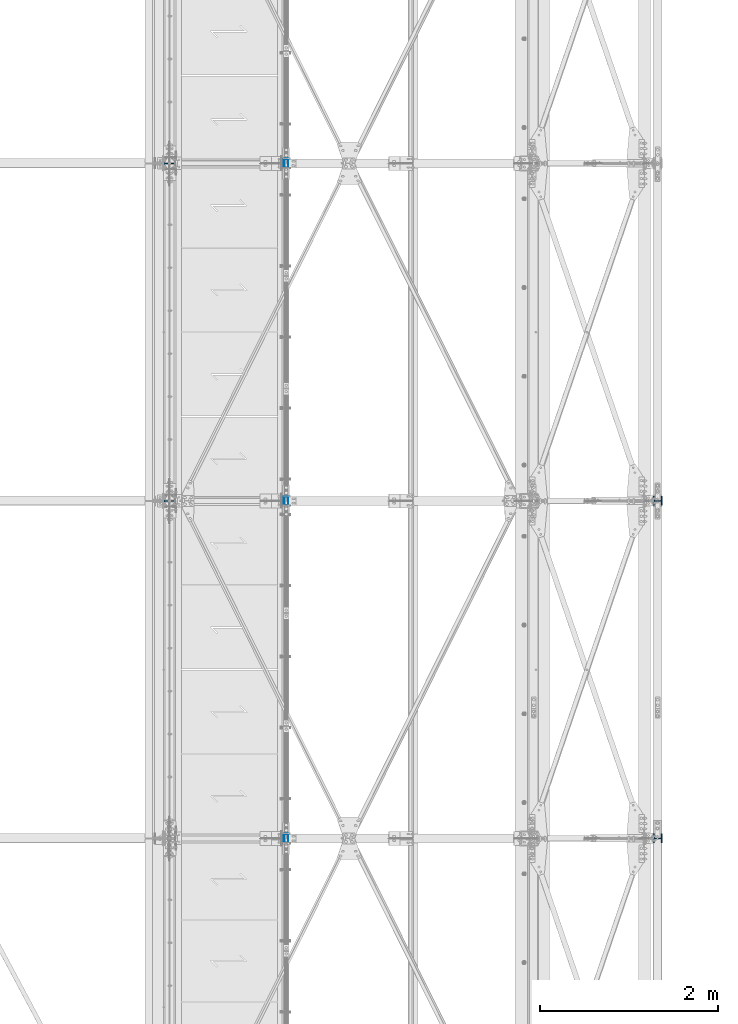
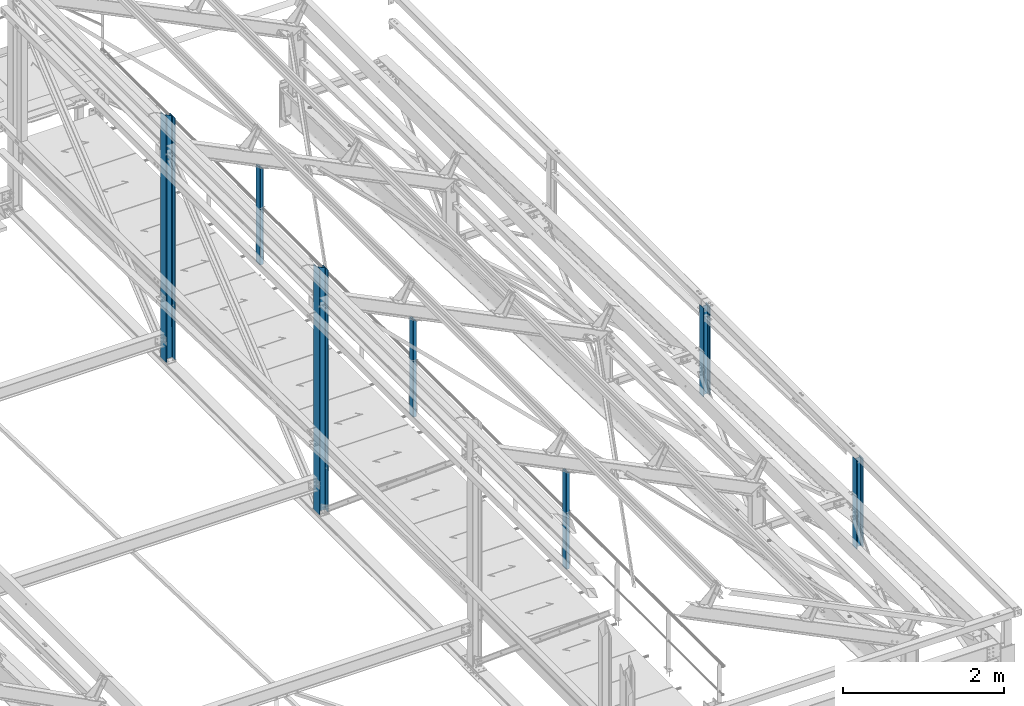
# One storey, part 17 of 496: 7 columns, 7 elements without a shape of their own.
"""IFC2X3 building model written with IfcOpenShell, lengths in millimetres."""

from ifc_helpers import new_model, si_unit, frame, origin_with_axes, origin_2d_with_axis, place, context, subcontext, project, spatial, hollow_rectangle, i_section, extrude, clip, halfspace, material, type_object, element, aggregate, save


model = new_model("IFC2X3")

# Units and contexts
model_context = context("Model", 3, precision=1e-05, world=origin_with_axes())
body_context = subcontext(model_context, "Body", "Model", "MODEL_VIEW")
ifc_project = project(units=[si_unit("LENGTHUNIT", "METRE", prefix="MILLI"), si_unit("AREAUNIT", "SQUARE_METRE"), si_unit("VOLUMEUNIT", "CUBIC_METRE"), si_unit("MASSUNIT", "GRAM", prefix="KILO"), si_unit("TIMEUNIT", "SECOND"), si_unit("PLANEANGLEUNIT", "RADIAN"), si_unit("SOLIDANGLEUNIT", "STERADIAN"), si_unit("THERMODYNAMICTEMPERATUREUNIT", "DEGREE_CELSIUS"), si_unit("LUMINOUSINTENSITYUNIT", "LUMEN")], contexts=[model_context])

# Site, building, storey
site_placement = place(None, origin_with_axes())
site = spatial("IfcSite", under=ifc_project, at=site_placement, CompositionType="ELEMENT")
building_placement = place(site_placement, origin_with_axes())
building = spatial("IfcBuilding", under=site, at=building_placement, Name="Undefined", CompositionType="ELEMENT")
storey_placement = place(building_placement, origin_with_axes())
storey = spatial("IfcBuildingStorey", under=building, at=storey_placement, Name="Undefined", CompositionType="ELEMENT", Elevation=0.0)

# Assembly, column
assembly_1_placement = place(storey_placement, origin_with_axes())
assembly_1 = element("IfcElementAssembly", 1, at=assembly_1_placement, inside=storey, Name="MONTANT", AssemblyPlace="NOTDEFINED", PredefinedType="NOTDEFINED")
ifc_material_1 = material(Name="Undefined/S275-E28")
column_type_1 = type_object("IfcColumnType", Name="HEA140", PredefinedType="NOTDEFINED")
column_1_placement = place(assembly_1_placement, frame((34280.0, 11400.0, 7260.0), z_axis=(0.0, 0.0, 1.0), x_axis=(-1.0, 0.0, 0.0)))
column_1 = element("IfcColumn", 2, at=column_1_placement, type_object=column_type_1, material=ifc_material_1, Name="MONTANT", ObjectType="HEA140", context=body_context, shape_type="Clipping", body=[
    clip(extrude(i_section(OverallWidth=140.0, OverallDepth=133.0, WebThickness=5.5, FlangeThickness=8.5, FilletRadius=12.0, at=origin_2d_with_axis()), frame((0.0, 0.0, 3730.84210522584), z_axis=(0.0, 0.0, -1.0), x_axis=(0.0, 1.0, 0.0)), (0.0, 0.0, 1.0), 3730.84), halfspace(frame((-66.5, 70.0, 3654.3071165161), z_axis=(-0.441220937981244, -6.28179308850765e-09, 0.89739850896185), x_axis=(0.89739850896185, 0.0, 0.441220937981244)), False)),
])
aggregate(assembly_1, [column_1])

assembly_2_placement = place(storey_placement, origin_with_axes())
assembly_2 = element("IfcElementAssembly", 3, at=assembly_2_placement, inside=storey, Name="MONTANT", AssemblyPlace="NOTDEFINED", PredefinedType="NOTDEFINED")
column_2_placement = place(assembly_2_placement, frame((34280.0, 7600.0, 7260.0), z_axis=(0.0, 0.0, 1.0), x_axis=(-1.0, 0.0, 0.0)))
column_2 = element("IfcColumn", 4, at=column_2_placement, type_object=column_type_1, material=ifc_material_1, Name="MONTANT", ObjectType="HEA140", context=body_context, shape_type="Clipping", body=[
    clip(extrude(i_section(OverallWidth=140.0, OverallDepth=133.0, WebThickness=5.5, FlangeThickness=8.5, FilletRadius=12.0, at=origin_2d_with_axis()), frame((0.0, 0.0, 3730.84210522584), z_axis=(0.0, 0.0, -1.0), x_axis=(0.0, 1.0, 0.0)), (0.0, 0.0, 1.0), 3730.84), halfspace(frame((-66.5, 70.0, 3654.3071165161), z_axis=(-0.441220937981244, -6.28179308850765e-09, 0.89739850896185), x_axis=(0.89739850896185, 0.0, 0.441220937981244)), False)),
])
aggregate(assembly_2, [column_2])

assembly_3_placement = place(storey_placement, origin_with_axes())
assembly_3 = element("IfcElementAssembly", 5, at=assembly_3_placement, inside=storey, AssemblyPlace="NOTDEFINED", PredefinedType="NOTDEFINED")
column_type_2 = type_object("IfcColumnType", Name="HEA100", PredefinedType="NOTDEFINED")
column_3_placement = place(assembly_3_placement, frame((39777.0, 3800.0, 7100.00000925125), z_axis=(0.0, 0.0, 1.0), x_axis=(1.0, 0.0, 0.0)))
column_3 = element("IfcColumn", 6, at=column_3_placement, type_object=column_type_2, material=ifc_material_1, ObjectType="HEA100", context=body_context, shape_type="SweptSolid", body=[
    extrude(i_section(OverallWidth=100.0, OverallDepth=96.0, WebThickness=5.0, FlangeThickness=8.0, FilletRadius=12.0, at=origin_2d_with_axis()), frame((0.0, 0.0, 1344.99999074875), z_axis=(0.0, 0.0, -1.0), x_axis=(0.0, 1.0, 0.0)), (0.0, 0.0, 1.0), 1345.0),
])
aggregate(assembly_3, [column_3])

assembly_4_placement = place(storey_placement, origin_with_axes())
assembly_4 = element("IfcElementAssembly", 7, at=assembly_4_placement, inside=storey, AssemblyPlace="NOTDEFINED", PredefinedType="NOTDEFINED")
column_4_placement = place(assembly_4_placement, frame((39777.0, 7600.0, 7100.00037857899), z_axis=(0.0, 0.0, 1.0), x_axis=(1.0, 0.0, 0.0)))
column_4 = element("IfcColumn", 8, at=column_4_placement, type_object=column_type_2, material=ifc_material_1, ObjectType="HEA100", context=body_context, shape_type="SweptSolid", body=[
    extrude(i_section(OverallWidth=100.0, OverallDepth=96.0, WebThickness=5.0, FlangeThickness=8.0, FilletRadius=12.0, at=origin_2d_with_axis()), frame((0.0, 0.0, 1344.99962142101), z_axis=(0.0, 0.0, -1.0), x_axis=(0.0, 1.0, 0.0)), (0.0, 0.0, 1.0), 1345.0),
])
aggregate(assembly_4, [column_4])

assembly_5_placement = place(storey_placement, origin_with_axes())
assembly_5 = element("IfcElementAssembly", 9, at=assembly_5_placement, inside=storey, AssemblyPlace="NOTDEFINED", PredefinedType="NOTDEFINED")
ifc_material_2 = material(Name="Undefined/S235-E24")
column_type_3 = type_object("IfcColumnType", PredefinedType="NOTDEFINED")
column_5_placement = place(assembly_5_placement, frame((35593.9917140619, 11400.0, 8250.0), z_axis=(0.0, 0.0, 1.0), x_axis=(0.0, -1.0, 0.0)))
column_5 = element("IfcColumn", 10, at=column_5_placement, type_object=column_type_3, material=ifc_material_2, context=body_context, shape_type="Clipping", body=[
    clip(extrude(hollow_rectangle(XDim=50.0, YDim=100.0, WallThickness=3.0, InnerFilletRadius=3.0, OuterFilletRadius=6.0, at=origin_2d_with_axis()), frame((0.0, 0.0, 1472.89728020347), z_axis=(0.0, 0.0, -1.0), x_axis=(0.0, 1.0, 0.0)), (0.0, 0.0, 1.0), 1472.9), halfspace(frame((0.0, -38.9853790466659, 1479.68377536489), z_axis=(0.0, -0.442968789899336, -0.896537032796258), x_axis=(1.0, 0.0, 0.0)), True)),
])
aggregate(assembly_5, [column_5])

assembly_6_placement = place(storey_placement, origin_with_axes())
assembly_6 = element("IfcElementAssembly", 11, at=assembly_6_placement, inside=storey, AssemblyPlace="NOTDEFINED", PredefinedType="NOTDEFINED")
column_6_placement = place(assembly_6_placement, frame((35593.9917140619, 3800.0, 8250.0), z_axis=(0.0, 0.0, 1.0), x_axis=(0.0, -1.0, 0.0)))
column_6 = element("IfcColumn", 12, at=column_6_placement, type_object=column_type_3, material=ifc_material_2, context=body_context, shape_type="Clipping", body=[
    clip(extrude(hollow_rectangle(XDim=50.0, YDim=100.0, WallThickness=3.0, InnerFilletRadius=3.0, OuterFilletRadius=6.0, at=origin_2d_with_axis()), frame((0.0, 0.0, 1472.89728020347), z_axis=(0.0, 0.0, -1.0), x_axis=(0.0, 1.0, 0.0)), (0.0, 0.0, 1.0), 1472.9), halfspace(frame((0.0, -38.9853790466659, 1479.68377536489), z_axis=(0.0, -0.442968789899336, -0.896537032796258), x_axis=(1.0, 0.0, 0.0)), True)),
])
aggregate(assembly_6, [column_6])

assembly_7_placement = place(storey_placement, origin_with_axes())
assembly_7 = element("IfcElementAssembly", 13, at=assembly_7_placement, inside=storey, AssemblyPlace="NOTDEFINED", PredefinedType="NOTDEFINED")
column_7_placement = place(assembly_7_placement, frame((35593.9917140619, 7600.0, 8250.0), z_axis=(0.0, 0.0, 1.0), x_axis=(0.0, -1.0, 0.0)))
column_7 = element("IfcColumn", 14, at=column_7_placement, type_object=column_type_3, material=ifc_material_2, context=body_context, shape_type="Clipping", body=[
    clip(extrude(hollow_rectangle(XDim=50.0, YDim=100.0, WallThickness=3.0, InnerFilletRadius=3.0, OuterFilletRadius=6.0, at=origin_2d_with_axis()), frame((0.0, 0.0, 1472.89728020347), z_axis=(0.0, 0.0, -1.0), x_axis=(0.0, 1.0, 0.0)), (0.0, 0.0, 1.0), 1472.9), halfspace(frame((0.0, -38.9853790466659, 1479.68377536489), z_axis=(0.0, -0.442968789899336, -0.896537032796258), x_axis=(1.0, 0.0, 0.0)), True)),
])
aggregate(assembly_7, [column_7])

save(model, "model.ifc")
